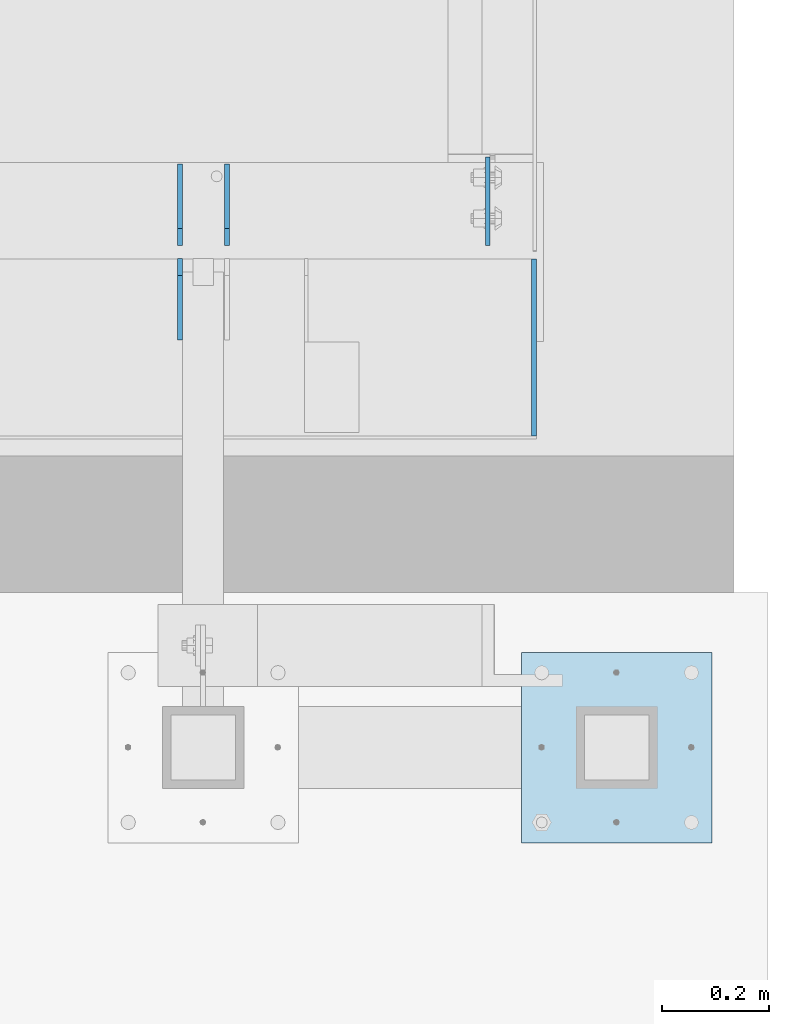
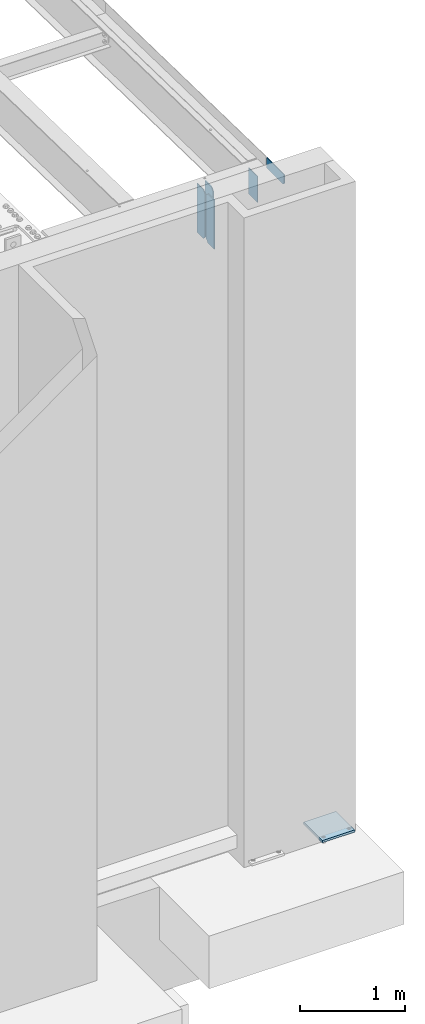
# One storey, part 1567 of 1763: 6 plates, 2 elements without a shape of their own.
"""IFC2X3 building model written with IfcOpenShell, lengths in millimetres."""

from ifc_helpers import new_model, si_unit, frame, origin_with_axes, place, context, subcontext, project, spatial, faceted_brep, material, type_object, element, aggregate, save


model = new_model("IFC2X3")

# Units and contexts
model_context = context("Model", 3, precision=1e-05, world=origin_with_axes())
body_context = subcontext(model_context, "Body", "Model", "MODEL_VIEW")
ifc_project = project(units=[si_unit("LENGTHUNIT", "METRE", prefix="MILLI"), si_unit("AREAUNIT", "SQUARE_METRE"), si_unit("VOLUMEUNIT", "CUBIC_METRE"), si_unit("MASSUNIT", "GRAM", prefix="KILO"), si_unit("TIMEUNIT", "SECOND"), si_unit("PLANEANGLEUNIT", "RADIAN"), si_unit("SOLIDANGLEUNIT", "STERADIAN"), si_unit("THERMODYNAMICTEMPERATUREUNIT", "DEGREE_CELSIUS"), si_unit("LUMINOUSINTENSITYUNIT", "LUMEN")], contexts=[model_context])

# Site, building, storey
site_placement = place(None, origin_with_axes())
site = spatial("IfcSite", under=ifc_project, at=site_placement, CompositionType="ELEMENT")
building_placement = place(site_placement, origin_with_axes())
building = spatial("IfcBuilding", under=site, at=building_placement, Name="Undefined", CompositionType="ELEMENT")
storey_placement = place(building_placement, origin_with_axes())
storey = spatial("IfcBuildingStorey", under=building, at=storey_placement, Name="Undefined", CompositionType="ELEMENT", Elevation=0.0)

# Assembly, plates
assembly_1_placement = place(storey_placement, origin_with_axes())
assembly_1 = element("IfcElementAssembly", 1, at=assembly_1_placement, inside=storey, Name="BEAM", AssemblyPlace="NOTDEFINED", PredefinedType="RIGID_FRAME")
ifc_material = material(Name="STEEL/A36")
plate_type_1 = type_object("IfcPlateType", PredefinedType="NOTDEFINED")
plate_1_placement = place(assembly_1_placement, frame((-21251.2997735727, -13728.6998186171, 12211.0500000202), z_axis=(0.0, 0.0, 1.0), x_axis=(0.0, -1.0, 0.0)))
plate_1 = element("IfcPlate", 2, at=plate_1_placement, type_object=plate_type_1, material=ifc_material, Name="PLATE", context=body_context, shape_type="Brep", body=[
    faceted_brep([(0.0, -4.76249999999982, 0.0), (3.8198777474463e-11, -4.76249999978609, 120.649999999834), (3.45607986673713e-11, 4.76250000024447, 120.649999999841), (0.0, 4.76249999999982, 0.0), (330.200012207031, -4.76249999978609, 120.650001525879), (330.200012207031, 4.76250000021537, 120.650001525879), (330.200012207031, -4.76249999996799, 19.0499992370605), (330.200012207031, 4.76250000003347, 19.0499992370605), (311.150012969971, -4.76250000000073, 0.0), (311.150012969971, 4.76250000000073, 0.0)], [[[0, 1, 2, 3]], [[1, 4, 5, 2]], [[4, 6, 7, 5]], [[6, 8, 9, 7]], [[8, 0, 3, 9]], [[5, 7, 9, 3, 2]], [[8, 6, 4, 1, 0]]]),
])
plate_type_2 = type_object("IfcPlateType", PredefinedType="NOTDEFINED")
plate_2_placement = place(assembly_1_placement, frame((-21911.700556465, -13880.3060686171, 11590.3375), z_axis=(0.0, 0.0, 1.0), x_axis=(0.0, 1.0, 0.0)))
plate_2 = element("IfcPlate", 3, at=plate_2_placement, type_object=plate_type_2, material=ifc_material, Name="PLATE", context=body_context, shape_type="Brep", body=[
    faceted_brep([(0.0, -4.76249999999982, 0.0), (0.0, -4.76250000012806, 568.325012206604), (0.0, 4.7624999999025, 568.325012206606), (0.0, 4.76249999999982, 0.0), (120.649993896484, -4.76250000000073, 568.325012207031), (120.649993896484, 4.76250000000073, 568.325012207031), (152.399993896484, -4.76250000000073, 536.575012207031), (152.399993896484, 4.76250000000073, 536.575012207031), (152.399993896484, -4.76250000000073, 31.75), (152.399993896484, 4.76250000000073, 31.75), (120.650001525879, -4.76249999999709, 0.0), (120.650001525879, 4.76249999999709, 0.0)], [[[0, 1, 2, 3]], [[1, 4, 5, 2]], [[4, 6, 7, 5]], [[6, 8, 9, 7]], [[8, 10, 11, 9]], [[10, 0, 3, 11]], [[5, 7, 9, 11, 3, 2]], [[10, 8, 6, 4, 1, 0]]]),
])
plate_3_placement = place(assembly_1_placement, frame((-21824.388056465, -13704.0935686171, 11590.3375), z_axis=(0.0, 0.0, 1.0), x_axis=(0.0, 1.0, 0.0)))
plate_3 = element("IfcPlate", 4, at=plate_3_placement, type_object=plate_type_2, material=ifc_material, Name="PLATE", context=body_context, shape_type="Brep", body=[
    faceted_brep([(0.0, -4.76250000000073, 31.75), (0.0, -4.76250000012078, 536.575012206626), (0.0, 4.76249999990978, 536.575012206629), (0.0, 4.76250000000073, 31.75), (31.75, -4.76250000012806, 568.325012206604), (31.75, 4.7624999999025, 568.325012206606), (152.399993896484, -4.76250000000073, 568.325012207031), (152.399993896484, 4.76250000000073, 568.325012207031), (152.400009155272, -4.76249999948777, 5.45696821063757e-12), (152.400009155273, 4.76250000051368, 3.63797880709171e-12), (31.75, -4.76250000000073, 0.0), (31.75, 4.76250000000073, 0.0)], [[[0, 1, 2, 3]], [[1, 4, 5, 2]], [[4, 6, 7, 5]], [[6, 8, 9, 7]], [[8, 10, 11, 9]], [[10, 0, 3, 11]], [[5, 7, 9, 11, 3, 2]], [[10, 8, 6, 4, 1, 0]]]),
])
plate_4_placement = place(assembly_1_placement, frame((-21911.700556465, -13704.0935686171, 11590.3375), z_axis=(0.0, 0.0, 1.0), x_axis=(0.0, 1.0, 0.0)))
plate_4 = element("IfcPlate", 5, at=plate_4_placement, type_object=plate_type_2, material=ifc_material, Name="PLATE", context=body_context, shape_type="Brep", body=[
    faceted_brep([(0.0, -4.76250000000073, 31.75), (0.0, -4.76250000012078, 536.575012206626), (0.0, 4.76249999990978, 536.575012206629), (0.0, 4.76250000000073, 31.75), (31.75, -4.76250000012806, 568.325012206604), (31.75, 4.7624999999025, 568.325012206606), (152.399993896484, -4.76250000000073, 568.325012207031), (152.399993896484, 4.76250000000073, 568.325012207031), (152.400009155272, -4.76249999948777, 5.45696821063757e-12), (152.400009155273, 4.76250000051368, 3.63797880709171e-12), (31.75, -4.76250000000073, 0.0), (31.75, 4.76250000000073, 0.0)], [[[0, 1, 2, 3]], [[1, 4, 5, 2]], [[4, 6, 7, 5]], [[6, 8, 9, 7]], [[8, 10, 11, 9]], [[10, 0, 3, 11]], [[5, 7, 9, 11, 3, 2]], [[10, 8, 6, 4, 1, 0]]]),
])

# Assembly, plate
assembly_2_placement = place(storey_placement, origin_with_axes())
assembly_2 = element("IfcElementAssembly", 6, at=assembly_2_placement, inside=storey, Name="FRAME", AssemblyPlace="NOTDEFINED", PredefinedType="RIGID_FRAME")
plate_type_3 = type_object("IfcPlateType", PredefinedType="NOTDEFINED")
plate_5_placement = place(assembly_2_placement, frame((-21275.1128611525, -14462.8432982799, 5079.99999999999), z_axis=(1.0, 0.0, 0.0), x_axis=(0.0, -1.0, 0.0)))
plate_5 = element("IfcPlate", 7, at=plate_5_placement, type_object=plate_type_3, material=ifc_material, Name="PLATE", context=body_context, shape_type="Brep", body=[
    faceted_brep([(0.0, -12.6999999999971, -1.81898940354586e-12), (0.0, -12.6999999999998, 355.600006103516), (0.0, 12.6999999999998, 355.600006103516), (0.0, 12.6999999999971, -1.81898940354586e-12), (355.600006103516, -12.6999999999998, 355.600006103516), (355.600006103516, 12.6999999999998, 355.600006103516), (355.600006103516, -12.6999999999998, 0.0), (355.600006103516, 12.6999999999998, 0.0)], [[[0, 1, 2, 3]], [[1, 4, 5, 2]], [[4, 6, 7, 5]], [[6, 0, 3, 7]], [[5, 7, 3, 2]], [[6, 4, 1, 0]]]),
])
aggregate(assembly_2, [plate_5])

# Plate
plate_type_4 = type_object("IfcPlateType", PredefinedType="NOTDEFINED")
plate_6_placement = place(assembly_1_placement, frame((-21337.8187736984, -13704.0935686171, 12127.1640902963), z_axis=(0.0, 1.0, 0.0), x_axis=(0.0, 0.0, -1.0)))
plate_6 = element("IfcPlate", 8, at=plate_6_placement, type_object=plate_type_4, material=ifc_material, Name="PLATE", context=body_context, shape_type="Brep", body=[
    faceted_brep([(0.0, -3.96900000000096, 0.0), (0.0, -3.96900000000096, 165.100006103516), (0.0, 3.96900000000096, 165.100006103516), (0.0, 3.96900000000096, 0.0), (304.799987792969, -3.96900000000096, 165.100006103516), (304.799987792969, 3.96900000000096, 165.100006103516), (304.799987792969, -3.96900000000096, -3.63797880709171e-11), (304.799987792969, 3.96900000000096, -3.63797880709171e-11)], [[[0, 1, 2, 3]], [[1, 4, 5, 2]], [[4, 6, 7, 5]], [[6, 0, 3, 7]], [[5, 7, 3, 2]], [[6, 4, 1, 0]]]),
])

aggregate(assembly_1, [plate_2, plate_3, plate_4, plate_1, plate_6])

save(model, "model.ifc")
